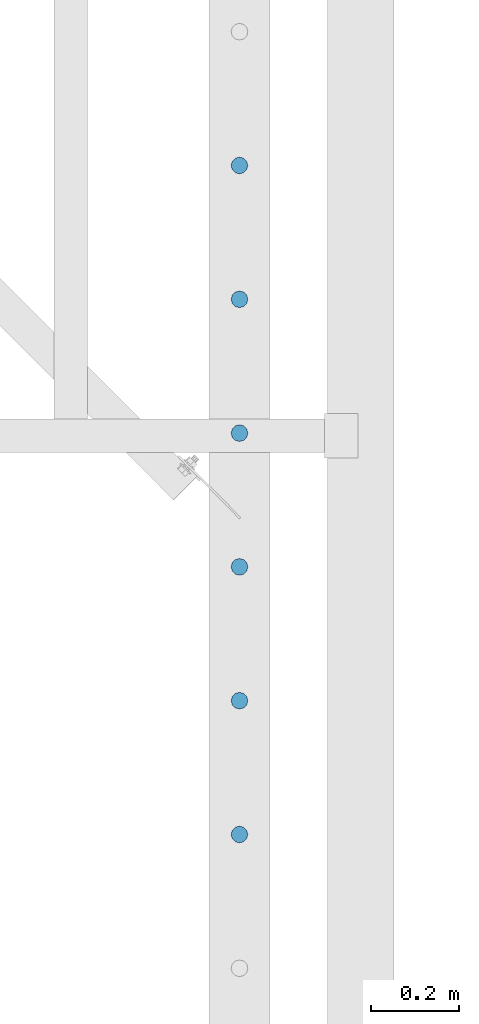
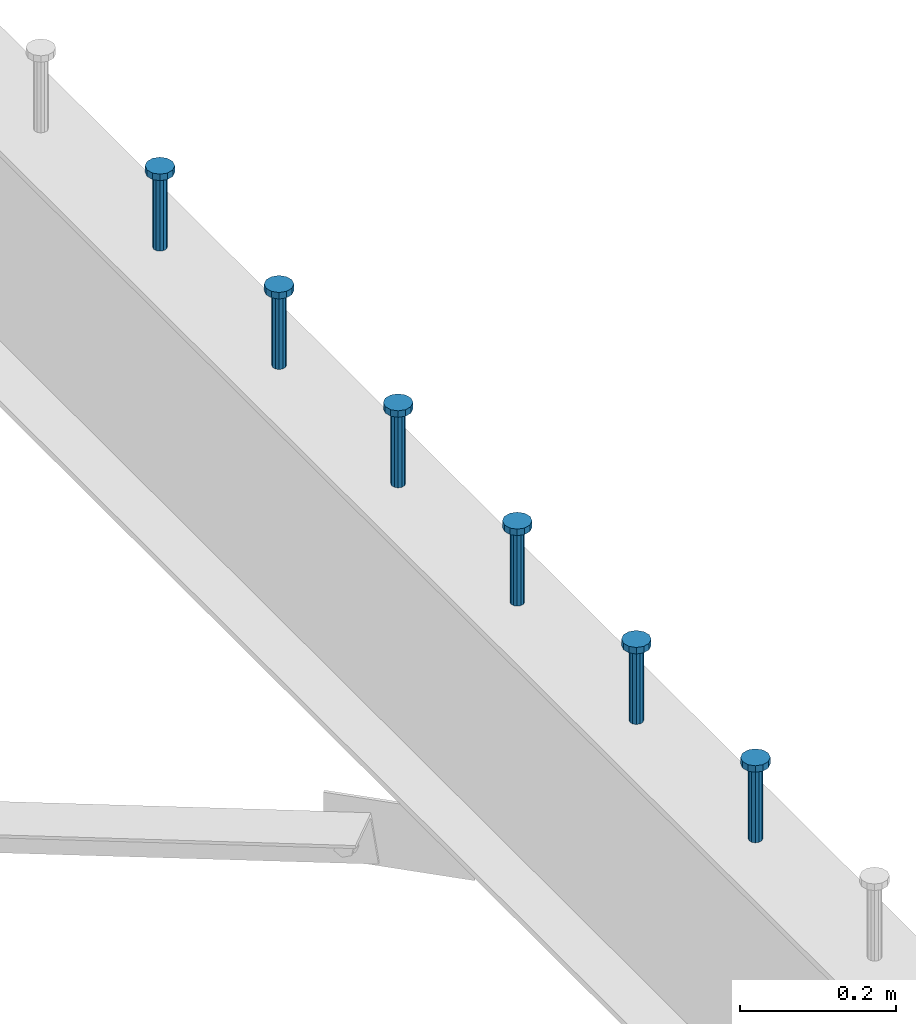
# One storey, part 198 of 975: 6 columns.
"""IFC2X3 building model written with IfcOpenShell, lengths in millimetres."""

from ifc_helpers import new_model, si_unit, frame, origin_with_axes, place, context, subcontext, project, spatial, faceted_brep, material, type_object, element, save


model = new_model("IFC2X3")

# Units and contexts
model_context = context("Model", 3, precision=1e-05, world=origin_with_axes())
body_context = subcontext(model_context, "Body", "Model", "MODEL_VIEW")
ifc_project = project(units=[si_unit("LENGTHUNIT", "METRE", prefix="MILLI"), si_unit("AREAUNIT", "SQUARE_METRE"), si_unit("VOLUMEUNIT", "CUBIC_METRE"), si_unit("MASSUNIT", "GRAM", prefix="KILO"), si_unit("TIMEUNIT", "SECOND"), si_unit("PLANEANGLEUNIT", "RADIAN"), si_unit("SOLIDANGLEUNIT", "STERADIAN"), si_unit("THERMODYNAMICTEMPERATUREUNIT", "DEGREE_CELSIUS"), si_unit("LUMINOUSINTENSITYUNIT", "LUMEN")], contexts=[model_context])

# Site, building, storey
site_placement = place(None, origin_with_axes())
site = spatial("IfcSite", under=ifc_project, at=site_placement, CompositionType="ELEMENT")
building_placement = place(site_placement, origin_with_axes())
building = spatial("IfcBuilding", under=site, at=building_placement, Name="Undefined", CompositionType="ELEMENT")
storey_placement = place(building_placement, origin_with_axes())
storey = spatial("IfcBuildingStorey", under=building, at=storey_placement, Name="Undefined", CompositionType="ELEMENT", Elevation=0.0)

# Columns
ifc_material = material(Name="STEEL/A108")
column_type = type_object("IfcColumnType", Name="STUD_3/4-DIA", PredefinedType="NOTDEFINED")
column_1_placement = place(storey_placement, frame((26644.6662714101, 7921.625, 3937.0), z_axis=(0.0, 1.0, 0.0), x_axis=(0.0, 0.0, 1.0)))
element("IfcColumn", 1, at=column_1_placement, inside=storey, type_object=column_type, material=ifc_material, ObjectType="STUD_3/4-DIA", context=body_context, shape_type="Brep", body=[
    faceted_brep([(0.0, -9.52000045776367, 0.0), (0.0, -8.25, -4.76000022888184), (115.57, -8.25, -4.76000022888184), (115.57, -9.52000045776367, 0.0), (0.0, -4.76000022888184, -8.25), (115.57, -4.76000022888184, -8.25), (0.0, 0.0, -9.52000045776367), (115.57, 0.0, -9.52000045776367), (0.0, 4.76000022888184, -8.25), (115.57, 4.76000022888184, -8.25), (0.0, 8.25, -4.76000022888184), (115.57, 8.25, -4.76000022888184), (0.0, 9.52000045776367, 0.0), (115.57, 9.52000045776367, 0.0), (0.0, 8.25, 4.76000022888184), (115.57, 8.25, 4.76000022888184), (0.0, 4.76000022888184, 8.25), (115.57, 4.76000022888184, 8.25), (0.0, 0.0, 9.52000045776367), (115.57, 0.0, 9.52000045776367), (0.0, -4.76000022888184, 8.25), (115.57, -4.76000022888184, 8.25), (0.0, -8.25, 4.76000022888184), (115.57, -8.25, 4.76000022888184), (116.84, -16.5, -9.52000045776367), (116.84, -19.0499992370605, 0.0), (116.84, -9.52000045776367, -16.5), (116.84, 0.0, -19.0499992370605), (116.84, 9.52000045776367, -16.5), (116.84, 16.5, -9.52000045776367), (116.84, 19.0499992370605, 0.0), (116.84, 16.5, 9.52000045776367), (116.84, 9.52000045776367, 16.5), (116.84, 0.0, 19.0499992370605), (116.84, -9.52000045776367, 16.5), (116.84, -16.5, 9.52000045776367), (127.0, -16.5, -9.52000045776367), (127.0, -19.0499992370605, 0.0), (127.0, -9.52000045776367, -16.5), (127.0, 0.0, -19.0499992370605), (127.0, 9.52000045776367, -16.5), (127.0, 16.5, -9.52000045776367), (127.0, 19.0499992370605, 0.0), (127.0, 16.5, 9.52000045776367), (127.0, 9.52000045776367, 16.5), (127.0, 0.0, 19.0499992370605), (127.0, -9.52000045776367, 16.5), (127.0, -16.5, 9.52000045776367)], [[[0, 1, 2, 3]], [[1, 4, 5, 2]], [[4, 6, 7, 5]], [[6, 8, 9, 7]], [[8, 10, 11, 9]], [[10, 12, 13, 11]], [[12, 14, 15, 13]], [[14, 16, 17, 15]], [[16, 18, 19, 17]], [[18, 20, 21, 19]], [[20, 22, 23, 21]], [[22, 0, 3, 23]], [[22, 20, 18, 16, 14, 12, 10, 8, 6, 4, 1, 0]], [[3, 2, 24, 25]], [[2, 5, 26, 24]], [[5, 7, 27, 26]], [[7, 9, 28, 27]], [[9, 11, 29, 28]], [[11, 13, 30, 29]], [[13, 15, 31, 30]], [[15, 17, 32, 31]], [[17, 19, 33, 32]], [[19, 21, 34, 33]], [[21, 23, 35, 34]], [[23, 3, 25, 35]], [[25, 24, 36, 37]], [[24, 26, 38, 36]], [[26, 27, 39, 38]], [[27, 28, 40, 39]], [[28, 29, 41, 40]], [[29, 30, 42, 41]], [[30, 31, 43, 42]], [[31, 32, 44, 43]], [[32, 33, 45, 44]], [[33, 34, 46, 45]], [[34, 35, 47, 46]], [[35, 25, 37, 47]], [[38, 39, 40, 41, 42, 43, 44, 45, 46, 47, 37, 36]]]),
])
column_2_placement = place(storey_placement, frame((26644.6662714101, 7616.825, 3937.0), z_axis=(0.0, 1.0, 0.0), x_axis=(0.0, 0.0, 1.0)))
element("IfcColumn", 2, at=column_2_placement, inside=storey, type_object=column_type, material=ifc_material, ObjectType="STUD_3/4-DIA", context=body_context, shape_type="Brep", body=[
    faceted_brep([(0.0, -9.52000045776367, 0.0), (0.0, -8.25, -4.76000022888184), (115.57, -8.25, -4.76000022888184), (115.57, -9.52000045776367, 0.0), (0.0, -4.76000022888184, -8.25), (115.57, -4.76000022888184, -8.25), (0.0, 0.0, -9.52000045776367), (115.57, 0.0, -9.52000045776367), (0.0, 4.76000022888184, -8.25), (115.57, 4.76000022888184, -8.25), (0.0, 8.25, -4.76000022888184), (115.57, 8.25, -4.76000022888184), (0.0, 9.52000045776367, 0.0), (115.57, 9.52000045776367, 0.0), (0.0, 8.25, 4.76000022888184), (115.57, 8.25, 4.76000022888184), (0.0, 4.76000022888184, 8.25), (115.57, 4.76000022888184, 8.25), (0.0, 0.0, 9.52000045776367), (115.57, 0.0, 9.52000045776367), (0.0, -4.76000022888184, 8.25), (115.57, -4.76000022888184, 8.25), (0.0, -8.25, 4.76000022888184), (115.57, -8.25, 4.76000022888184), (116.84, -16.5, -9.52000045776367), (116.84, -19.0499992370605, 0.0), (116.84, -9.52000045776367, -16.5), (116.84, 0.0, -19.0499992370605), (116.84, 9.52000045776367, -16.5), (116.84, 16.5, -9.52000045776367), (116.84, 19.0499992370605, 0.0), (116.84, 16.5, 9.52000045776367), (116.84, 9.52000045776367, 16.5), (116.84, 0.0, 19.0499992370605), (116.84, -9.52000045776367, 16.5), (116.84, -16.5, 9.52000045776367), (127.0, -16.5, -9.52000045776367), (127.0, -19.0499992370605, 0.0), (127.0, -9.52000045776367, -16.5), (127.0, 0.0, -19.0499992370605), (127.0, 9.52000045776367, -16.5), (127.0, 16.5, -9.52000045776367), (127.0, 19.0499992370605, 0.0), (127.0, 16.5, 9.52000045776367), (127.0, 9.52000045776367, 16.5), (127.0, 0.0, 19.0499992370605), (127.0, -9.52000045776367, 16.5), (127.0, -16.5, 9.52000045776367)], [[[0, 1, 2, 3]], [[1, 4, 5, 2]], [[4, 6, 7, 5]], [[6, 8, 9, 7]], [[8, 10, 11, 9]], [[10, 12, 13, 11]], [[12, 14, 15, 13]], [[14, 16, 17, 15]], [[16, 18, 19, 17]], [[18, 20, 21, 19]], [[20, 22, 23, 21]], [[22, 0, 3, 23]], [[22, 20, 18, 16, 14, 12, 10, 8, 6, 4, 1, 0]], [[3, 2, 24, 25]], [[2, 5, 26, 24]], [[5, 7, 27, 26]], [[7, 9, 28, 27]], [[9, 11, 29, 28]], [[11, 13, 30, 29]], [[13, 15, 31, 30]], [[15, 17, 32, 31]], [[17, 19, 33, 32]], [[19, 21, 34, 33]], [[21, 23, 35, 34]], [[23, 3, 25, 35]], [[25, 24, 36, 37]], [[24, 26, 38, 36]], [[26, 27, 39, 38]], [[27, 28, 40, 39]], [[28, 29, 41, 40]], [[29, 30, 42, 41]], [[30, 31, 43, 42]], [[31, 32, 44, 43]], [[32, 33, 45, 44]], [[33, 34, 46, 45]], [[34, 35, 47, 46]], [[35, 25, 37, 47]], [[38, 39, 40, 41, 42, 43, 44, 45, 46, 47, 37, 36]]]),
])
column_3_placement = place(storey_placement, frame((26644.6662714101, 7312.025, 3937.0), z_axis=(0.0, 1.0, 0.0), x_axis=(0.0, 0.0, 1.0)))
element("IfcColumn", 3, at=column_3_placement, inside=storey, type_object=column_type, material=ifc_material, ObjectType="STUD_3/4-DIA", context=body_context, shape_type="Brep", body=[
    faceted_brep([(0.0, -9.52000045776367, 0.0), (0.0, -8.25, -4.76000022888184), (115.57, -8.25, -4.76000022888184), (115.57, -9.52000045776367, 0.0), (0.0, -4.76000022888184, -8.25), (115.57, -4.76000022888184, -8.25), (0.0, 0.0, -9.52000045776367), (115.57, 0.0, -9.52000045776367), (0.0, 4.76000022888184, -8.25), (115.57, 4.76000022888184, -8.25), (0.0, 8.25, -4.76000022888184), (115.57, 8.25, -4.76000022888184), (0.0, 9.52000045776367, 0.0), (115.57, 9.52000045776367, 0.0), (0.0, 8.25, 4.76000022888184), (115.57, 8.25, 4.76000022888184), (0.0, 4.76000022888184, 8.25), (115.57, 4.76000022888184, 8.25), (0.0, 0.0, 9.52000045776367), (115.57, 0.0, 9.52000045776367), (0.0, -4.76000022888184, 8.25), (115.57, -4.76000022888184, 8.25), (0.0, -8.25, 4.76000022888184), (115.57, -8.25, 4.76000022888184), (116.84, -16.5, -9.52000045776367), (116.84, -19.0499992370605, 0.0), (116.84, -9.52000045776367, -16.5), (116.84, 0.0, -19.0499992370605), (116.84, 9.52000045776367, -16.5), (116.84, 16.5, -9.52000045776367), (116.84, 19.0499992370605, 0.0), (116.84, 16.5, 9.52000045776367), (116.84, 9.52000045776367, 16.5), (116.84, 0.0, 19.0499992370605), (116.84, -9.52000045776367, 16.5), (116.84, -16.5, 9.52000045776367), (127.0, -16.5, -9.52000045776367), (127.0, -19.0499992370605, 0.0), (127.0, -9.52000045776367, -16.5), (127.0, 0.0, -19.0499992370605), (127.0, 9.52000045776367, -16.5), (127.0, 16.5, -9.52000045776367), (127.0, 19.0499992370605, 0.0), (127.0, 16.5, 9.52000045776367), (127.0, 9.52000045776367, 16.5), (127.0, 0.0, 19.0499992370605), (127.0, -9.52000045776367, 16.5), (127.0, -16.5, 9.52000045776367)], [[[0, 1, 2, 3]], [[1, 4, 5, 2]], [[4, 6, 7, 5]], [[6, 8, 9, 7]], [[8, 10, 11, 9]], [[10, 12, 13, 11]], [[12, 14, 15, 13]], [[14, 16, 17, 15]], [[16, 18, 19, 17]], [[18, 20, 21, 19]], [[20, 22, 23, 21]], [[22, 0, 3, 23]], [[22, 20, 18, 16, 14, 12, 10, 8, 6, 4, 1, 0]], [[3, 2, 24, 25]], [[2, 5, 26, 24]], [[5, 7, 27, 26]], [[7, 9, 28, 27]], [[9, 11, 29, 28]], [[11, 13, 30, 29]], [[13, 15, 31, 30]], [[15, 17, 32, 31]], [[17, 19, 33, 32]], [[19, 21, 34, 33]], [[21, 23, 35, 34]], [[23, 3, 25, 35]], [[25, 24, 36, 37]], [[24, 26, 38, 36]], [[26, 27, 39, 38]], [[27, 28, 40, 39]], [[28, 29, 41, 40]], [[29, 30, 42, 41]], [[30, 31, 43, 42]], [[31, 32, 44, 43]], [[32, 33, 45, 44]], [[33, 34, 46, 45]], [[34, 35, 47, 46]], [[35, 25, 37, 47]], [[38, 39, 40, 41, 42, 43, 44, 45, 46, 47, 37, 36]]]),
])
column_4_placement = place(storey_placement, frame((26644.6662714101, 7007.225, 3937.0), z_axis=(0.0, 1.0, 0.0), x_axis=(0.0, 0.0, 1.0)))
element("IfcColumn", 4, at=column_4_placement, inside=storey, type_object=column_type, material=ifc_material, ObjectType="STUD_3/4-DIA", context=body_context, shape_type="Brep", body=[
    faceted_brep([(0.0, -9.52000045776367, 0.0), (0.0, -8.25, -4.76000022888184), (115.57, -8.25, -4.76000022888184), (115.57, -9.52000045776367, 0.0), (0.0, -4.76000022888184, -8.25), (115.57, -4.76000022888184, -8.25), (0.0, 0.0, -9.52000045776367), (115.57, 0.0, -9.52000045776367), (0.0, 4.76000022888184, -8.25), (115.57, 4.76000022888184, -8.25), (0.0, 8.25, -4.76000022888184), (115.57, 8.25, -4.76000022888184), (0.0, 9.52000045776367, 0.0), (115.57, 9.52000045776367, 0.0), (0.0, 8.25, 4.76000022888184), (115.57, 8.25, 4.76000022888184), (0.0, 4.76000022888184, 8.25), (115.57, 4.76000022888184, 8.25), (0.0, 0.0, 9.52000045776367), (115.57, 0.0, 9.52000045776367), (0.0, -4.76000022888184, 8.25), (115.57, -4.76000022888184, 8.25), (0.0, -8.25, 4.76000022888184), (115.57, -8.25, 4.76000022888184), (116.84, -16.5, -9.52000045776367), (116.84, -19.0499992370605, 0.0), (116.84, -9.52000045776367, -16.5), (116.84, 0.0, -19.0499992370605), (116.84, 9.52000045776367, -16.5), (116.84, 16.5, -9.52000045776367), (116.84, 19.0499992370605, 0.0), (116.84, 16.5, 9.52000045776367), (116.84, 9.52000045776367, 16.5), (116.84, 0.0, 19.0499992370605), (116.84, -9.52000045776367, 16.5), (116.84, -16.5, 9.52000045776367), (127.0, -16.5, -9.52000045776367), (127.0, -19.0499992370605, 0.0), (127.0, -9.52000045776367, -16.5), (127.0, 0.0, -19.0499992370605), (127.0, 9.52000045776367, -16.5), (127.0, 16.5, -9.52000045776367), (127.0, 19.0499992370605, 0.0), (127.0, 16.5, 9.52000045776367), (127.0, 9.52000045776367, 16.5), (127.0, 0.0, 19.0499992370605), (127.0, -9.52000045776367, 16.5), (127.0, -16.5, 9.52000045776367)], [[[0, 1, 2, 3]], [[1, 4, 5, 2]], [[4, 6, 7, 5]], [[6, 8, 9, 7]], [[8, 10, 11, 9]], [[10, 12, 13, 11]], [[12, 14, 15, 13]], [[14, 16, 17, 15]], [[16, 18, 19, 17]], [[18, 20, 21, 19]], [[20, 22, 23, 21]], [[22, 0, 3, 23]], [[22, 20, 18, 16, 14, 12, 10, 8, 6, 4, 1, 0]], [[3, 2, 24, 25]], [[2, 5, 26, 24]], [[5, 7, 27, 26]], [[7, 9, 28, 27]], [[9, 11, 29, 28]], [[11, 13, 30, 29]], [[13, 15, 31, 30]], [[15, 17, 32, 31]], [[17, 19, 33, 32]], [[19, 21, 34, 33]], [[21, 23, 35, 34]], [[23, 3, 25, 35]], [[25, 24, 36, 37]], [[24, 26, 38, 36]], [[26, 27, 39, 38]], [[27, 28, 40, 39]], [[28, 29, 41, 40]], [[29, 30, 42, 41]], [[30, 31, 43, 42]], [[31, 32, 44, 43]], [[32, 33, 45, 44]], [[33, 34, 46, 45]], [[34, 35, 47, 46]], [[35, 25, 37, 47]], [[38, 39, 40, 41, 42, 43, 44, 45, 46, 47, 37, 36]]]),
])
column_5_placement = place(storey_placement, frame((26644.6662714101, 6702.425, 3937.0), z_axis=(0.0, 1.0, 0.0), x_axis=(0.0, 0.0, 1.0)))
element("IfcColumn", 5, at=column_5_placement, inside=storey, type_object=column_type, material=ifc_material, ObjectType="STUD_3/4-DIA", context=body_context, shape_type="Brep", body=[
    faceted_brep([(0.0, -9.52000045776367, 0.0), (0.0, -8.25, -4.76000022888184), (115.57, -8.25, -4.76000022888184), (115.57, -9.52000045776367, 0.0), (0.0, -4.76000022888184, -8.25), (115.57, -4.76000022888184, -8.25), (0.0, 0.0, -9.52000045776367), (115.57, 0.0, -9.52000045776367), (0.0, 4.76000022888184, -8.25), (115.57, 4.76000022888184, -8.25), (0.0, 8.25, -4.76000022888184), (115.57, 8.25, -4.76000022888184), (0.0, 9.52000045776367, 0.0), (115.57, 9.52000045776367, 0.0), (0.0, 8.25, 4.76000022888184), (115.57, 8.25, 4.76000022888184), (0.0, 4.76000022888184, 8.25), (115.57, 4.76000022888184, 8.25), (0.0, 0.0, 9.52000045776367), (115.57, 0.0, 9.52000045776367), (0.0, -4.76000022888184, 8.25), (115.57, -4.76000022888184, 8.25), (0.0, -8.25, 4.76000022888184), (115.57, -8.25, 4.76000022888184), (116.84, -16.5, -9.52000045776367), (116.84, -19.0499992370605, 0.0), (116.84, -9.52000045776367, -16.5), (116.84, 0.0, -19.0499992370605), (116.84, 9.52000045776367, -16.5), (116.84, 16.5, -9.52000045776367), (116.84, 19.0499992370605, 0.0), (116.84, 16.5, 9.52000045776367), (116.84, 9.52000045776367, 16.5), (116.84, 0.0, 19.0499992370605), (116.84, -9.52000045776367, 16.5), (116.84, -16.5, 9.52000045776367), (127.0, -16.5, -9.52000045776367), (127.0, -19.0499992370605, 0.0), (127.0, -9.52000045776367, -16.5), (127.0, 0.0, -19.0499992370605), (127.0, 9.52000045776367, -16.5), (127.0, 16.5, -9.52000045776367), (127.0, 19.0499992370605, 0.0), (127.0, 16.5, 9.52000045776367), (127.0, 9.52000045776367, 16.5), (127.0, 0.0, 19.0499992370605), (127.0, -9.52000045776367, 16.5), (127.0, -16.5, 9.52000045776367)], [[[0, 1, 2, 3]], [[1, 4, 5, 2]], [[4, 6, 7, 5]], [[6, 8, 9, 7]], [[8, 10, 11, 9]], [[10, 12, 13, 11]], [[12, 14, 15, 13]], [[14, 16, 17, 15]], [[16, 18, 19, 17]], [[18, 20, 21, 19]], [[20, 22, 23, 21]], [[22, 0, 3, 23]], [[22, 20, 18, 16, 14, 12, 10, 8, 6, 4, 1, 0]], [[3, 2, 24, 25]], [[2, 5, 26, 24]], [[5, 7, 27, 26]], [[7, 9, 28, 27]], [[9, 11, 29, 28]], [[11, 13, 30, 29]], [[13, 15, 31, 30]], [[15, 17, 32, 31]], [[17, 19, 33, 32]], [[19, 21, 34, 33]], [[21, 23, 35, 34]], [[23, 3, 25, 35]], [[25, 24, 36, 37]], [[24, 26, 38, 36]], [[26, 27, 39, 38]], [[27, 28, 40, 39]], [[28, 29, 41, 40]], [[29, 30, 42, 41]], [[30, 31, 43, 42]], [[31, 32, 44, 43]], [[32, 33, 45, 44]], [[33, 34, 46, 45]], [[34, 35, 47, 46]], [[35, 25, 37, 47]], [[38, 39, 40, 41, 42, 43, 44, 45, 46, 47, 37, 36]]]),
])
column_6_placement = place(storey_placement, frame((26644.6662714101, 6397.625, 3937.0), z_axis=(0.0, 1.0, 0.0), x_axis=(0.0, 0.0, 1.0)))
element("IfcColumn", 6, at=column_6_placement, inside=storey, type_object=column_type, material=ifc_material, ObjectType="STUD_3/4-DIA", context=body_context, shape_type="Brep", body=[
    faceted_brep([(0.0, -9.52000045776367, 0.0), (0.0, -8.25, -4.76000022888184), (115.57, -8.25, -4.76000022888184), (115.57, -9.52000045776367, 0.0), (0.0, -4.76000022888184, -8.25), (115.57, -4.76000022888184, -8.25), (0.0, 0.0, -9.52000045776367), (115.57, 0.0, -9.52000045776367), (0.0, 4.76000022888184, -8.25), (115.57, 4.76000022888184, -8.25), (0.0, 8.25, -4.76000022888184), (115.57, 8.25, -4.76000022888184), (0.0, 9.52000045776367, 0.0), (115.57, 9.52000045776367, 0.0), (0.0, 8.25, 4.76000022888184), (115.57, 8.25, 4.76000022888184), (0.0, 4.76000022888184, 8.25), (115.57, 4.76000022888184, 8.25), (0.0, 0.0, 9.52000045776367), (115.57, 0.0, 9.52000045776367), (0.0, -4.76000022888184, 8.25), (115.57, -4.76000022888184, 8.25), (0.0, -8.25, 4.76000022888184), (115.57, -8.25, 4.76000022888184), (116.84, -16.5, -9.52000045776367), (116.84, -19.0499992370605, 0.0), (116.84, -9.52000045776367, -16.5), (116.84, 0.0, -19.0499992370605), (116.84, 9.52000045776367, -16.5), (116.84, 16.5, -9.52000045776367), (116.84, 19.0499992370605, 0.0), (116.84, 16.5, 9.52000045776367), (116.84, 9.52000045776367, 16.5), (116.84, 0.0, 19.0499992370605), (116.84, -9.52000045776367, 16.5), (116.84, -16.5, 9.52000045776367), (127.0, -16.5, -9.52000045776367), (127.0, -19.0499992370605, 0.0), (127.0, -9.52000045776367, -16.5), (127.0, 0.0, -19.0499992370605), (127.0, 9.52000045776367, -16.5), (127.0, 16.5, -9.52000045776367), (127.0, 19.0499992370605, 0.0), (127.0, 16.5, 9.52000045776367), (127.0, 9.52000045776367, 16.5), (127.0, 0.0, 19.0499992370605), (127.0, -9.52000045776367, 16.5), (127.0, -16.5, 9.52000045776367)], [[[0, 1, 2, 3]], [[1, 4, 5, 2]], [[4, 6, 7, 5]], [[6, 8, 9, 7]], [[8, 10, 11, 9]], [[10, 12, 13, 11]], [[12, 14, 15, 13]], [[14, 16, 17, 15]], [[16, 18, 19, 17]], [[18, 20, 21, 19]], [[20, 22, 23, 21]], [[22, 0, 3, 23]], [[22, 20, 18, 16, 14, 12, 10, 8, 6, 4, 1, 0]], [[3, 2, 24, 25]], [[2, 5, 26, 24]], [[5, 7, 27, 26]], [[7, 9, 28, 27]], [[9, 11, 29, 28]], [[11, 13, 30, 29]], [[13, 15, 31, 30]], [[15, 17, 32, 31]], [[17, 19, 33, 32]], [[19, 21, 34, 33]], [[21, 23, 35, 34]], [[23, 3, 25, 35]], [[25, 24, 36, 37]], [[24, 26, 38, 36]], [[26, 27, 39, 38]], [[27, 28, 40, 39]], [[28, 29, 41, 40]], [[29, 30, 42, 41]], [[30, 31, 43, 42]], [[31, 32, 44, 43]], [[32, 33, 45, 44]], [[33, 34, 46, 45]], [[34, 35, 47, 46]], [[35, 25, 37, 47]], [[38, 39, 40, 41, 42, 43, 44, 45, 46, 47, 37, 36]]]),
])

save(model, "model.ifc")
